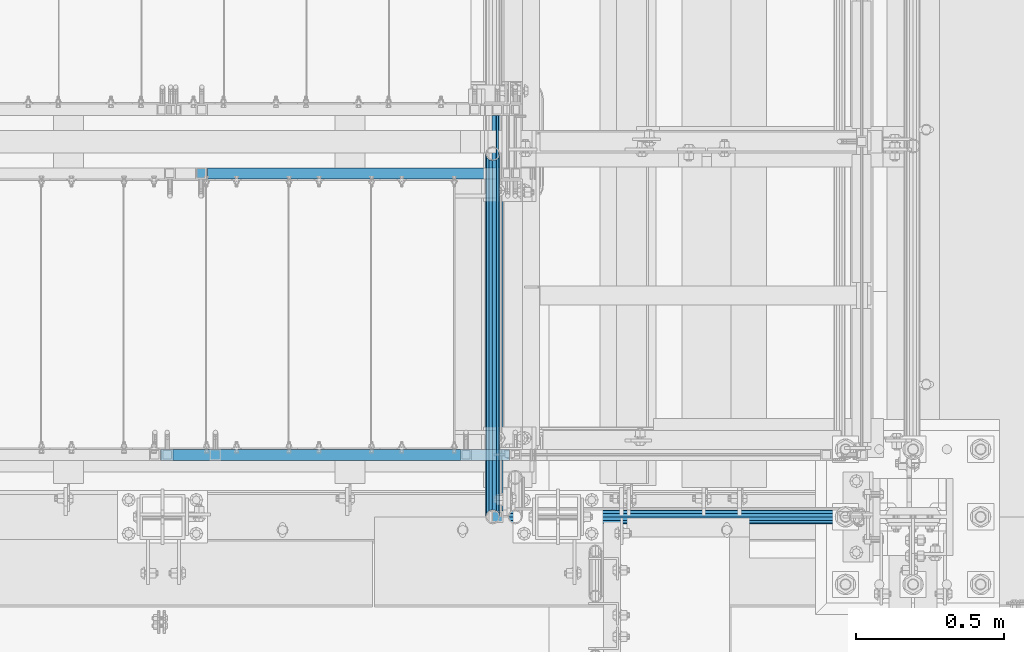
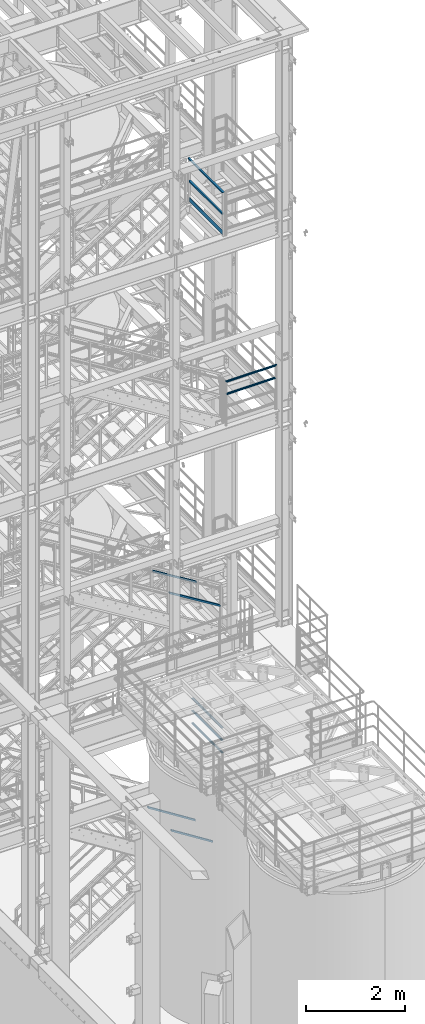
# One storey, part 950 of 1876: 8 beams, 4 members, 7 elements without a shape of their own.
"""IFC2X3 building model written with IfcOpenShell, lengths in millimetres."""

import ifcopenshell
import ifcopenshell.guid

model = None  # the IFC model being written
_history = None  # IfcOwnerHistory: only IFC2X3 demands one
_inside = {}  # id of a spatial element -> (the spatial element, [elements in it])
_under = {}  # id of a project, library or spatial element -> (it, [spatial elements below it])
_declared = {}  # id of a project -> (the project, [libraries it declares])
_typed = {}  # id of a type object -> (the type object, [elements of that type])
_made_of = {}  # id of a material, layer set ... -> (it, [elements and type objects made of it])


def new_model(schema):
    """Start an empty IFC model of exactly this schema.

    Asked for "IFC4X3", IfcOpenShell would pick the latest addendum, in which some entities
    have other attributes; the version numbers below select the first issue.
    IFC2X3 requires an IfcOwnerHistory on every rooted entity: one is made here for all.
    """
    global model, _history
    if schema == "IFC4X3":
        model = ifcopenshell.file(schema_version=(4, 3, 0, 0))
    else:
        model = ifcopenshell.file(schema=schema)
    _inside.clear()
    _under.clear()
    _declared.clear()
    _typed.clear()
    _made_of.clear()
    _history = None
    if model.schema == "IFC2X3":
        org = make("IfcOrganization", Name="unknown")
        user = make(
            "IfcPersonAndOrganization",
            ThePerson=make("IfcPerson", FamilyName="unknown"),
            TheOrganization=org,
        )
        app = make(
            "IfcApplication",
            ApplicationDeveloper=org,
            Version="unknown",
            ApplicationFullName="unknown",
            ApplicationIdentifier="unknown",
        )
        _history = make(
            "IfcOwnerHistory",
            OwningUser=user,
            OwningApplication=app,
            ChangeAction="ADDED",
            CreationDate=0,
        )
    return model


def make(cls, **values):
    """One entity of the class cls with the attributes given. An attribute that is None is left unset."""
    return model.create_entity(
        cls, **{name: value for name, value in values.items() if value is not None}
    )


def rooted(cls, **values):
    """An entity with a GlobalId (a new one), such as an element, a storey or a relation."""
    return make(cls, GlobalId=ifcopenshell.guid.new(), OwnerHistory=_history, **values)


def si_unit(unit_type, name, prefix=None):
    """IfcSIUnit, for example si_unit("LENGTHUNIT", "METRE", prefix="MILLI")."""
    return make("IfcSIUnit", UnitType=unit_type, Prefix=prefix, Name=name)


def assignment(units):
    """IfcUnitAssignment: the units of a project."""
    return None if units is None else make("IfcUnitAssignment", Units=units)


def point(xyz):
    """IfcCartesianPoint."""
    return None if xyz is None else make("IfcCartesianPoint", Coordinates=xyz)


def direction(xyz):
    """IfcDirection."""
    return None if xyz is None else make("IfcDirection", DirectionRatios=xyz)


def frame(location, z_axis=None, x_axis=None):
    """IfcAxis2Placement3D, a coordinate frame: its origin and axes. An axis left out is left unset."""
    return make(
        "IfcAxis2Placement3D",
        Location=point(location),
        Axis=direction(z_axis),
        RefDirection=direction(x_axis),
    )


def origin_with_axes():
    """The frame at (0, 0, 0) with the z axis (0, 0, 1) and the x axis (1, 0, 0) written out."""
    return frame((0.0, 0.0, 0.0), z_axis=(0.0, 0.0, 1.0), x_axis=(1.0, 0.0, 0.0))


def place(relative_to, where):
    """IfcLocalPlacement: puts the frame where relative to a parent placement (None: the world)."""
    return make(
        "IfcLocalPlacement", PlacementRelTo=relative_to, RelativePlacement=where
    )


def context(
    kind, dimensions, precision=None, world=None, true_north=None, identifier=None
):
    """IfcGeometricRepresentationContext, for example the 3D "Model" context."""
    return make(
        "IfcGeometricRepresentationContext",
        ContextIdentifier=identifier,
        ContextType=kind,
        CoordinateSpaceDimension=dimensions,
        Precision=precision,
        WorldCoordinateSystem=world,
        TrueNorth=true_north,
    )


def subcontext(parent, identifier, kind, view, scale=None):
    """IfcGeometricRepresentationSubContext, for example "Body" below "Model"."""
    return make(
        "IfcGeometricRepresentationSubContext",
        ContextIdentifier=identifier,
        ContextType=kind,
        ParentContext=parent,
        TargetScale=scale,
        TargetView=view,
    )


def project(units=None, contexts=None):
    """IfcProject with its units and contexts."""
    return rooted(
        "IfcProject",
        Name="project",
        RepresentationContexts=contexts,
        UnitsInContext=assignment(units),
    )


def spatial(cls, under=None, at=None, **own):
    """A site, building, storey or space (cls), placed at a placement, below another one or the project."""
    s = rooted(cls, ObjectPlacement=at, **own)
    if under is not None:
        _under.setdefault(under.id(), (under, []))[1].append(s)
    return s


def faces_of(points, faces, orient=None, outer=None):
    """IfcFace entities. A face is a list of loops; a loop is a list of indices into points, from 0.

    orient and outer hold one flag for each loop. By default every Orientation is true, the
    first loop of a face is its IfcFaceOuterBound and the others are IfcFaceBound.
    """
    made = []
    for i, loops in enumerate(faces):
        bounds = []
        for j, loop in enumerate(loops):
            is_outer = j == 0 if outer is None else outer[i][j]
            bounds.append(
                make(
                    "IfcFaceOuterBound" if is_outer else "IfcFaceBound",
                    Bound=make("IfcPolyLoop", Polygon=[points[k] for k in loop]),
                    Orientation=True if orient is None else orient[i][j],
                )
            )
        made.append(make("IfcFace", Bounds=bounds))
    return made


def faceted_brep(points, faces, orient=None, outer=None, voids=None):
    """IfcFacetedBrep: a solid bounded by flat faces; with voids (closed shells), ...WithVoids."""
    shared = [point(p) for p in points]
    hull = make("IfcClosedShell", CfsFaces=faces_of(shared, faces, orient, outer))
    if voids is None:
        return make("IfcFacetedBrep", Outer=hull)
    return make(
        "IfcFacetedBrepWithVoids",
        Outer=hull,
        Voids=[
            make(cls, CfsFaces=faces_of(shared, fs, o, b)) for cls, fs, o, b in voids
        ],
    )


def shape(context_of_items, identifier, shape_type, items):
    """IfcShapeRepresentation: the items that make up one representation, for example the "Body"."""
    return make(
        "IfcShapeRepresentation",
        ContextOfItems=context_of_items,
        RepresentationIdentifier=identifier,
        RepresentationType=shape_type,
        Items=items,
    )


def material(Name=None, Category=None):
    """IfcMaterial."""
    return make("IfcMaterial", Name=Name, Category=Category)


def made_of(thing, what):
    """Note that an element or type object is made of a material, layer set ...; save() writes the relation."""
    if what is not None:
        _made_of.setdefault(what.id(), (what, []))[1].append(thing)
    return thing


def type_object(cls, material=None, **own):
    """A type object (cls), such as IfcWallType, which elements share."""
    return made_of(rooted(cls, **own), material)


def element(
    cls,
    number,
    at=None,
    inside=None,
    cuts=None,
    type_object=None,
    material=None,
    context=None,
    identifier="Body",
    shape_type=None,
    held_by="IfcProductDefinitionShape",
    body=None,
    shapes=None,
    **own,
):
    """One element of the class cls, such as IfcWall. Its Tag is "e" and its number.

    at: its placement. inside: the storey or other place that contains it. cuts: it is an
    opening in that element (IfcRelVoidsElement). A single representation is given by context,
    identifier, shape_type and body (its items); several are given by shapes. held_by: the class
    of the entity that holds the representations. save() writes the other relations.
    """
    e = rooted(cls, Tag="e%d" % number, ObjectPlacement=at, **own)
    if body is not None:
        shapes = [shape(context, identifier, shape_type, body)]
    if shapes is not None:
        e.Representation = make(held_by, Representations=shapes)
    if inside is not None:
        _inside.setdefault(inside.id(), (inside, []))[1].append(e)
    if cuts is not None:
        rooted(
            "IfcRelVoidsElement", RelatingBuildingElement=cuts, RelatedOpeningElement=e
        )
    if type_object is not None:
        _typed.setdefault(type_object.id(), (type_object, []))[1].append(e)
    return made_of(e, material)


def aggregate(whole, parts):
    """IfcRelAggregates: a whole, such as a stair, and the parts it consists of."""
    return rooted("IfcRelAggregates", RelatingObject=whole, RelatedObjects=parts)


def save(model, path):
    """Write the relations noted so far, then the file.

    IfcRelAggregates (storeys below a building ...), IfcRelContainedInSpatialStructure (elements
    in a storey), IfcRelDefinesByType, IfcRelAssociatesMaterial and IfcRelDeclares: one each for
    every whole, place, type object, material and project.
    """
    for whole, parts in _under.values():
        aggregate(whole, parts)
    for where, things in _inside.values():
        rooted(
            "IfcRelContainedInSpatialStructure",
            RelatedElements=things,
            RelatingStructure=where,
        )
    for kind, things in _typed.values():
        rooted("IfcRelDefinesByType", RelatedObjects=things, RelatingType=kind)
    for what, things in _made_of.values():
        rooted("IfcRelAssociatesMaterial", RelatedObjects=things, RelatingMaterial=what)
    for by, libraries in _declared.values():
        rooted("IfcRelDeclares", RelatingContext=by, RelatedDefinitions=libraries)
    model.write(path)


model = new_model("IFC2X3")

# Units and contexts
model_context = context("Model", 3, precision=1e-05, world=origin_with_axes())
body_context = subcontext(model_context, "Body", "Model", "MODEL_VIEW")
ifc_project = project(units=[si_unit("LENGTHUNIT", "METRE", prefix="MILLI"), si_unit("AREAUNIT", "SQUARE_METRE"), si_unit("VOLUMEUNIT", "CUBIC_METRE"), si_unit("MASSUNIT", "GRAM", prefix="KILO"), si_unit("TIMEUNIT", "SECOND"), si_unit("PLANEANGLEUNIT", "RADIAN"), si_unit("SOLIDANGLEUNIT", "STERADIAN"), si_unit("THERMODYNAMICTEMPERATUREUNIT", "DEGREE_CELSIUS"), si_unit("LUMINOUSINTENSITYUNIT", "LUMEN")], contexts=[model_context])

# Site, building, storey
site_placement = place(None, origin_with_axes())
site = spatial("IfcSite", under=ifc_project, at=site_placement, CompositionType="ELEMENT")
building_placement = place(site_placement, origin_with_axes())
building = spatial("IfcBuilding", under=site, at=building_placement, Name="Undefined", CompositionType="ELEMENT")
storey_placement = place(building_placement, origin_with_axes())
storey = spatial("IfcBuildingStorey", under=building, at=storey_placement, Name="Undefined", CompositionType="ELEMENT", Elevation=0.0)

# Assembly, beams
assembly_1_placement = place(storey_placement, origin_with_axes())
assembly_1 = element("IfcElementAssembly", 1, at=assembly_1_placement, inside=storey, Name="RAIL", AssemblyPlace="NOTDEFINED", PredefinedType="RIGID_FRAME")
ifc_material_1 = material()
beam_type_1 = type_object("IfcBeamType", Name="PIPE1-1/2SCH40", PredefinedType="NOTDEFINED")
beam_1_placement = place(assembly_1_placement, frame((6273.80016410903, -7112.0, 14081.125), z_axis=(0.0, 0.0, -1.0), x_axis=(1.0, 0.0, 0.0)))
beam_1 = element("IfcBeam", 2, at=beam_1_placement, type_object=beam_type_1, material=ifc_material_1, Name="RAIL", ObjectType="PIPE1-1/2SCH40", context=body_context, shape_type="Brep", body=[
    faceted_brep([(0.0, 24.1299999999992, 0.0), (12.0650000000064, 20.8971929933177, -12.0649999999987), (12.0650000000064, 20.8971929933177, 12.0649999999987), (12.0650000000064, -20.8971929933177, 12.0649999999987), (12.0650000000064, -20.8971929933177, -12.0649999999987), (0.0, -24.1299999999992, 0.0), (20.8971929933249, -12.0650000000005, 20.8971929933177), (20.8971929933249, -12.0650000000005, 15.8661214311796), (15.2545715621445, -17.7076214311801, 10.2235000000001), (12.5151929933249, -20.4470000000001, 0.0), (15.2545715621445, -17.7076214311801, -10.2235000000001), (20.8971929933249, -12.0650000000005, -15.8661214311796), (20.8971929933249, -12.0650000000005, -20.8971929933177), (24.1300000000063, 0.0, -20.4470000000001), (24.1300000000063, 0.0, -24.130000000001), (21.3906214311868, -10.2235000000001, -17.7076214311819), (21.3906214311868, 10.2235000000001, -17.7076214311819), (20.8971929933249, 12.0650000000005, -15.8661214311796), (20.8971929933249, 12.0650000000005, -20.8971929933177), (15.2545715621445, 17.7076214311801, -10.2235000000001), (12.5151929933249, 20.4470000000001, 0.0), (15.2545715621445, 17.7076214311801, 10.2235000000001), (20.8971929933249, 12.0650000000005, 15.8661214311796), (20.8971929933249, 12.0650000000005, 20.8971929933177), (21.3906214311868, 10.2235000000001, 17.7076214311819), (24.1300000000064, 0.0, 20.4470000000001), (24.1300000000064, 0.0, 24.130000000001), (21.3906214311868, -10.2235000000001, 17.7076214311819), (1154.11233589097, 24.1300000000001, 0.0), (1142.04733589097, 20.8971929933186, -12.0649999999996), (1133.21514289765, 12.0649999999996, -20.8971929933186), (1154.11233589097, -24.1300000000001, 0.0), (1142.04733589097, -20.8971929933186, -12.0649999999996), (1142.04733589097, -20.8971929933186, 12.0649999999996), (1133.21514289765, -12.0649999999996, 20.8971929933186), (1133.21514289765, -12.0649999999996, -20.8971929933186), (1129.98233589097, 0.0, -24.1300000000001), (1132.72171445979, 10.2235000000001, -17.7076214311801), (1129.98233589097, 0.0, -20.4470000000001), (1133.21514289765, 12.0649999999996, -15.8661214311805), (1133.21514289765, -12.0649999999996, -15.8661214311805), (1132.72171445979, -10.2235000000001, -17.7076214311801), (1138.85776432883, -17.7076214311801, -10.2235000000001), (1141.59714289765, -20.4470000000001, 0.0), (1138.85776432883, -17.7076214311801, 10.2235000000001), (1133.21514289765, -12.0649999999996, 15.8661214311805), (1132.72171445979, -10.2235000000001, 17.7076214311801), (1129.98233589097, 0.0, 20.4470000000001), (1129.98233589097, 0.0, 24.1300000000001), (1133.21514289765, 12.0649999999996, 20.8971929933186), (1142.04733589097, 20.8971929933186, 12.0649999999996), (1133.21514289765, 12.0649999999996, 15.8661214311805), (1138.85776432883, 17.7076214311801, 10.2235000000001), (1141.59714289765, 20.4470000000001, 0.0), (1138.85776432883, 17.7076214311801, -10.2235000000001), (1132.72171445979, 10.2235000000001, 17.7076214311801)], [[[0, 1, 2]], [[3, 4, 5]], [[6, 7, 8, 9, 10, 11, 12, 4, 3]], [[13, 14, 12, 11, 15]], [[16, 17, 18, 14, 13]], [[2, 1, 18, 17, 19, 20, 21, 22, 23]], [[23, 22, 24, 25, 26]], [[26, 25, 27, 7, 6]], [[1, 0, 28, 29]], [[18, 1, 29, 30]], [[31, 32, 33]], [[6, 3, 33, 34]], [[3, 5, 31, 33]], [[5, 4, 32, 31]], [[4, 12, 35, 32]], [[12, 14, 36, 35]], [[14, 18, 30, 36]], [[37, 38, 36, 30, 39]], [[40, 35, 36, 38, 41]], [[33, 32, 35, 40, 42, 43, 44, 45, 34]], [[34, 45, 46, 47, 48]], [[26, 6, 34, 48]], [[2, 23, 49, 50]], [[23, 26, 48, 49]], [[0, 2, 50, 28]], [[28, 50, 29]], [[49, 51, 52, 53, 54, 39, 30, 29, 50]], [[48, 47, 55, 51, 49]], [[25, 24, 55, 47]], [[55, 24, 22, 21, 52, 51]], [[21, 20, 53, 52]], [[20, 19, 54, 53]], [[19, 17, 16, 37, 39, 54]], [[16, 13, 38, 37]], [[13, 15, 41, 38]], [[41, 15, 11, 10, 42, 40]], [[10, 9, 43, 42]], [[9, 8, 44, 43]], [[8, 7, 27, 46, 45, 44]], [[27, 25, 47, 46]]]),
])
beam_2_placement = place(assembly_1_placement, frame((6249.67016410903, -7112.0, 14385.925), z_axis=(0.0, 0.0, -1.0), x_axis=(1.0, 0.0, 0.0)))
beam_2 = element("IfcBeam", 3, at=beam_2_placement, type_object=beam_type_1, material=ifc_material_1, Name="RAIL", ObjectType="PIPE1-1/2SCH40", context=body_context, shape_type="Brep", body=[
    faceted_brep([(24.1300000000001, -20.4469999999999, 0.0), (34.3535000000002, -17.7076214311803, 10.2235000000001), (1168.01883589097, -17.7076214311801, 10.2235000000001), (1178.24233589097, -20.4470000000001, 0.0), (41.8376214311802, -10.2235000000001, 17.7076214311819), (1160.53471445979, -10.2235000000001, 17.7076214311801), (44.5770000000002, 0.0, 20.4470000000001), (1157.79533589097, 0.0, 20.4470000000001), (41.8376214311802, 10.2235000000001, 17.7076214311819), (1160.53471445979, 10.2235000000001, 17.7076214311801), (34.3535000000002, 17.7076214311803, 10.2235000000001), (1168.01883589097, 17.7076214311801, 10.2235000000001), (24.1300000000001, 20.4469999999999, 0.0), (1178.24233589097, 20.4470000000001, 0.0), (13.9065000000001, 17.7076214311803, -10.2235000000001), (1188.46583589097, 17.7076214311801, -10.2235000000001), (6.42237856882002, 10.2235000000001, -17.7076214311819), (1195.94995732215, 10.2235000000001, -17.7076214311801), (3.68299999999999, 0.0, -20.4470000000001), (1198.68933589097, 0.0, -20.4470000000001), (6.42237856882002, -10.2235000000001, -17.7076214311819), (1195.94995732215, -10.2235000000001, -17.7076214311801), (13.9065000000001, -17.7076214311803, -10.2235000000001), (1188.46583589097, -17.7076214311801, -10.2235000000001), (24.1299999999854, -24.1299999999992, 0.0), (12.0650000000064, -20.8971929933177, -12.0649999999987), (1190.30733589097, -20.8971929933186, -12.0649999999996), (1178.24233589097, -24.1300000000001, 0.0), (3.23280700668147, -12.0650000000001, -20.8971929933177), (1199.13952888429, -12.0649999999996, -20.8971929933186), (-1.45519152283669e-11, 0.0, -24.130000000001), (1202.37233589097, 0.0, -24.1300000000001), (3.23280700668147, 12.0650000000001, -20.8971929933177), (1199.13952888429, 12.0649999999996, -20.8971929933186), (12.0650000000064, 20.8971929933177, -12.0649999999987), (1190.30733589097, 20.8971929933186, -12.0649999999996), (24.1300000000047, 24.1299999999992, 0.0), (1178.24233589097, 24.1300000000001, 0.0), (36.1949999999997, 20.8971929933184, 12.0649999999987), (1166.17733589097, 20.8971929933186, 12.0649999999996), (45.0271929933187, 12.0650000000001, 20.8971929933177), (1157.34514289765, 12.0649999999996, 20.8971929933186), (48.2600000000002, 0.0, 24.130000000001), (1154.11233589097, 0.0, 24.1300000000001), (45.0271929933187, -12.0650000000001, 20.8971929933177), (1157.34514289765, -12.0649999999996, 20.8971929933186), (36.1949999999997, -20.8971929933184, 12.0649999999987), (1166.17733589097, -20.8971929933186, 12.0649999999996)], [[[0, 1, 2, 3]], [[1, 4, 5, 2]], [[4, 6, 7, 5]], [[6, 8, 9, 7]], [[8, 10, 11, 9]], [[10, 12, 13, 11]], [[12, 14, 15, 13]], [[14, 16, 17, 15]], [[16, 18, 19, 17]], [[18, 20, 21, 19]], [[20, 22, 23, 21]], [[22, 0, 3, 23]], [[24, 25, 26, 27]], [[25, 28, 29, 26]], [[28, 30, 31, 29]], [[30, 32, 33, 31]], [[32, 34, 35, 33]], [[34, 36, 37, 35]], [[36, 38, 39, 37]], [[38, 40, 41, 39]], [[40, 42, 43, 41]], [[42, 44, 45, 43]], [[44, 46, 47, 45]], [[46, 24, 27, 47]], [[29, 31, 33, 35, 37, 39, 41, 43, 45, 47, 27, 26], [5, 7, 9, 11, 13, 15, 17, 19, 21, 23, 3, 2]], [[46, 44, 42, 40, 38, 36, 34, 32, 30, 28, 25, 24], [22, 20, 18, 16, 14, 12, 10, 8, 6, 4, 1, 0]]]),
])
aggregate(assembly_1, [beam_1, beam_2])

assembly_2_placement = place(storey_placement, origin_with_axes())
assembly_2 = element("IfcElementAssembly", 4, at=assembly_2_placement, inside=storey, Name="RAIL", AssemblyPlace="NOTDEFINED", PredefinedType="RIGID_FRAME")
beam_3_placement = place(assembly_2_placement, frame((6197.60000000158, -5883.27500095479, 5292.725), z_axis=(0.0, 0.0, 1.0), x_axis=(0.0, -1.0, 0.0)))
beam_3 = element("IfcBeam", 5, at=beam_3_placement, type_object=beam_type_1, material=ifc_material_1, Name="RAIL", ObjectType="PIPE1-1/2SCH40", context=body_context, shape_type="Brep", body=[
    faceted_brep([(1207.82780681642, -12.0649999999996, 20.8971929933186), (1207.82780681642, -12.0649999999432, 15.8661214312369), (1207.33437837857, -10.2235000000001, 17.7076214311801), (1204.59499980973, 2.72848410531878e-12, 20.4470000000001), (1204.59499980973, 2.72848410531878e-12, 24.1300000000001), (1207.33437837854, 10.2235000000001, 17.7076214311801), (1207.82780681642, 12.065000000056, 15.8661214311242), (1207.82780681642, 12.0649999999996, 20.8971929933186), (1228.72499980973, 24.1300000000001, 0.0), (1216.65999980973, 20.8971929933186, 12.0649999999996), (1216.65999980973, 20.8971929933186, -12.0649999999996), (1213.47042824754, 17.7076214311801, 10.2235000000001), (1216.20980681636, 20.4470000000001, 0.0), (1213.47042824754, 17.7076214311801, -10.2235000000001), (1207.82780681642, 12.065000000056, -15.8661214311242), (1207.82780681642, 12.0649999999996, -20.8971929933186), (1207.33437837854, 10.2235000000001, -17.7076214311801), (1204.59499980973, 0.0, -20.4470000000001), (1204.59499980973, 0.0, -24.1300000000001), (1207.82780681642, -12.0649999999432, -15.8661214312369), (1207.82780681642, -12.0649999999996, -20.8971929933186), (1207.33437837857, -10.2235000000001, -17.7076214311801), (1228.72499980973, -24.1299999999437, 0.0), (1216.65999980973, -20.8971929933186, -12.0649999999996), (1216.65999980973, -20.8971929933186, 12.0649999999996), (1213.47042824765, -17.7076214311801, -10.2235000000001), (1216.20980681647, -20.4470000000001, 0.0), (1213.47042824765, -17.7076214311801, 10.2235000000001), (12.0650000000064, -20.8971929933177, -12.0649999999987), (20.8971929933249, -12.0650000000005, -20.8971929933177), (0.0, 24.1299999999992, 0.0), (12.0650000000064, 20.8971929933177, -12.0649999999987), (12.0650000000064, 20.8971929933177, 12.0649999999987), (20.8971929933249, 12.0650000000005, 20.8971929933177), (24.1300000000064, 0.0, 24.130000000001), (20.8971929933249, 12.0650000000005, -20.8971929933177), (24.1300000000063, 0.0, -24.130000000001), (24.1300000000063, 0.0, -20.4470000000001), (20.8971929933249, -12.0650000000005, -15.8661214311796), (21.3906214311868, -10.2235000000001, -17.7076214311819), (21.3906214311868, 10.2235000000001, -17.7076214311819), (20.8971929933249, 12.0650000000005, -15.8661214311796), (15.2545715621445, 17.7076214311801, -10.2235000000001), (12.5151929933249, 20.4470000000001, 0.0), (15.2545715621445, 17.7076214311801, 10.2235000000001), (20.8971929933249, 12.0650000000005, 15.8661214311796), (21.3906214311868, 10.2235000000001, 17.7076214311819), (24.1300000000064, 0.0, 20.4470000000001), (21.3906214311868, -10.2235000000001, 17.7076214311819), (20.8971929933249, -12.0650000000005, 15.8661214311796), (20.8971929933249, -12.0650000000005, 20.8971929933177), (12.0650000000064, -20.8971929933177, 12.0649999999987), (0.0, -24.1299999999992, 0.0), (15.2545715621445, -17.7076214311801, 10.2235000000001), (12.5151929933249, -20.4470000000001, 0.0), (15.2545715621445, -17.7076214311801, -10.2235000000001)], [[[0, 1, 2, 3, 4]], [[4, 3, 5, 6, 7]], [[8, 9, 10]], [[7, 6, 11, 12, 13, 14, 15, 10, 9]], [[16, 17, 18, 15, 14]], [[19, 20, 18, 17, 21]], [[22, 23, 24]], [[24, 23, 20, 19, 25, 26, 27, 1, 0]], [[28, 29, 20, 23]], [[30, 31, 32]], [[33, 34, 4, 7]], [[32, 33, 7, 9]], [[30, 32, 9, 8]], [[31, 30, 8, 10]], [[35, 31, 10, 15]], [[36, 35, 15, 18]], [[29, 36, 18, 20]], [[37, 36, 29, 38, 39]], [[40, 41, 35, 36, 37]], [[32, 31, 35, 41, 42, 43, 44, 45, 33]], [[33, 45, 46, 47, 34]], [[34, 47, 48, 49, 50]], [[34, 50, 0, 4]], [[50, 51, 24, 0]], [[51, 52, 22, 24]], [[52, 28, 23, 22]], [[51, 28, 52]], [[50, 49, 53, 54, 55, 38, 29, 28, 51]], [[55, 54, 26, 25]], [[21, 39, 38, 55, 25, 19]], [[37, 39, 21, 17]], [[40, 37, 17, 16]], [[42, 41, 40, 16, 14, 13]], [[43, 42, 13, 12]], [[44, 43, 12, 11]], [[5, 46, 45, 44, 11, 6]], [[47, 46, 5, 3]], [[48, 47, 3, 2]], [[53, 49, 48, 2, 1, 27]], [[54, 53, 27, 26]]]),
])
beam_4_placement = place(assembly_2_placement, frame((6197.59999999995, -7112.00000000001, 5597.525), z_axis=(0.0, 0.0, -1.0), x_axis=(0.0, 1.0, 0.0)))
beam_4 = element("IfcBeam", 6, at=beam_4_placement, type_object=beam_type_1, material=ifc_material_1, Name="RAIL", ObjectType="PIPE1-1/2SCH40", context=body_context, shape_type="Brep", body=[
    faceted_brep([(0.0, 24.1299999999992, 0.0), (12.0650000000064, 20.8971929933177, -12.0649999999987), (12.0650000000064, 20.8971929933177, 12.0649999999987), (12.0650000000064, -20.8971929933177, 12.0649999999987), (12.0650000000064, -20.8971929933177, -12.0649999999987), (0.0, -24.1299999999992, 0.0), (20.8971929933249, -12.0650000000005, 20.8971929933177), (20.8971929933249, -12.0650000000005, 15.8661214311796), (15.2545715621445, -17.7076214311801, 10.2235000000001), (12.5151929933249, -20.4470000000001, 0.0), (15.2545715621445, -17.7076214311801, -10.2235000000001), (20.8971929933249, -12.0650000000005, -15.8661214311796), (20.8971929933249, -12.0650000000005, -20.8971929933177), (24.1300000000063, 0.0, -20.4470000000001), (24.1300000000063, 0.0, -24.130000000001), (21.3906214311868, -10.2235000000001, -17.7076214311819), (21.3906214311868, 10.2235000000001, -17.7076214311819), (20.8971929933249, 12.0650000000005, -15.8661214311796), (20.8971929933249, 12.0650000000005, -20.8971929933177), (15.2545715621445, 17.7076214311801, -10.2235000000001), (12.5151929933249, 20.4470000000001, 0.0), (15.2545715621445, 17.7076214311801, 10.2235000000001), (20.8971929933249, 12.0650000000005, 15.8661214311796), (20.8971929933249, 12.0650000000005, 20.8971929933177), (21.3906214311868, 10.2235000000001, 17.7076214311819), (24.1300000000064, 0.0, 20.4470000000001), (24.1300000000064, 0.0, 24.130000000001), (21.3906214311868, -10.2235000000001, 17.7076214311819), (1228.72499980973, 24.1300000000001, 0.0), (1216.65999980973, 20.8971929933186, -12.0649999999996), (1207.82780681642, 12.0649999999996, -20.8971929933186), (1228.72499980973, -24.1299999999437, 0.0), (1216.65999980973, -20.8971929933186, -12.0649999999996), (1216.65999980973, -20.8971929933186, 12.0649999999996), (1207.82780681642, -12.0649999999996, 20.8971929933186), (1207.82780681642, -12.0649999999996, -20.8971929933186), (1204.59499980973, 0.0, -24.1300000000001), (1207.33437837854, 10.2235000000001, -17.7076214311801), (1204.59499980973, 0.0, -20.4470000000001), (1207.82780681642, 12.065000000056, -15.8661214311242), (1207.82780681642, -12.0649999999432, -15.8661214312369), (1207.33437837857, -10.2235000000001, -17.7076214311801), (1213.47042824765, -17.7076214311801, -10.2235000000001), (1216.20980681647, -20.4470000000001, 0.0), (1213.47042824765, -17.7076214311801, 10.2235000000001), (1207.82780681642, -12.0649999999432, 15.8661214312369), (1207.33437837857, -10.2235000000001, 17.7076214311801), (1204.59499980973, 2.72848410531878e-12, 20.4470000000001), (1204.59499980973, 2.72848410531878e-12, 24.1300000000001), (1207.82780681642, 12.0649999999996, 20.8971929933186), (1216.65999980973, 20.8971929933186, 12.0649999999996), (1207.82780681642, 12.065000000056, 15.8661214311242), (1213.47042824754, 17.7076214311801, 10.2235000000001), (1216.20980681636, 20.4470000000001, 0.0), (1213.47042824754, 17.7076214311801, -10.2235000000001), (1207.33437837854, 10.2235000000001, 17.7076214311801)], [[[0, 1, 2]], [[3, 4, 5]], [[6, 7, 8, 9, 10, 11, 12, 4, 3]], [[13, 14, 12, 11, 15]], [[16, 17, 18, 14, 13]], [[2, 1, 18, 17, 19, 20, 21, 22, 23]], [[23, 22, 24, 25, 26]], [[26, 25, 27, 7, 6]], [[1, 0, 28, 29]], [[18, 1, 29, 30]], [[31, 32, 33]], [[6, 3, 33, 34]], [[3, 5, 31, 33]], [[5, 4, 32, 31]], [[4, 12, 35, 32]], [[12, 14, 36, 35]], [[14, 18, 30, 36]], [[37, 38, 36, 30, 39]], [[40, 35, 36, 38, 41]], [[33, 32, 35, 40, 42, 43, 44, 45, 34]], [[34, 45, 46, 47, 48]], [[26, 6, 34, 48]], [[2, 23, 49, 50]], [[23, 26, 48, 49]], [[0, 2, 50, 28]], [[28, 50, 29]], [[49, 51, 52, 53, 54, 39, 30, 29, 50]], [[48, 47, 55, 51, 49]], [[25, 24, 55, 47]], [[55, 24, 22, 21, 52, 51]], [[21, 20, 53, 52]], [[20, 19, 54, 53]], [[19, 17, 16, 37, 39, 54]], [[16, 13, 38, 37]], [[13, 15, 41, 38]], [[41, 15, 11, 10, 42, 40]], [[10, 9, 43, 42]], [[9, 8, 44, 43]], [[8, 7, 27, 46, 45, 44]], [[27, 25, 47, 46]]]),
])
beam_5_placement = place(assembly_2_placement, frame((6197.59999999995, -7112.00000000001, 5902.325), z_axis=(0.0, 0.0, -1.0), x_axis=(0.0, 1.0, 0.0)))
beam_5 = element("IfcBeam", 7, at=beam_5_placement, type_object=beam_type_1, material=ifc_material_1, Name="RAIL", ObjectType="PIPE1-1/2SCH40", context=body_context, shape_type="Brep", body=[
    faceted_brep([(0.0, 24.1299999999992, 0.0), (12.0650000000064, 20.8971929933177, -12.0649999999987), (12.0650000000064, 20.8971929933177, 12.0649999999987), (12.0650000000064, -20.8971929933177, 12.0649999999987), (12.0650000000064, -20.8971929933177, -12.0649999999987), (0.0, -24.1299999999992, 0.0), (20.8971929933249, -12.0650000000005, 20.8971929933177), (20.8971929933249, -12.0650000000005, 15.8661214311796), (15.2545715621445, -17.7076214311801, 10.2235000000001), (12.5151929933249, -20.4470000000001, 0.0), (15.2545715621445, -17.7076214311801, -10.2235000000001), (20.8971929933249, -12.0650000000005, -15.8661214311796), (20.8971929933249, -12.0650000000005, -20.8971929933177), (24.1300000000063, 0.0, -20.4470000000001), (24.1300000000063, 0.0, -24.130000000001), (21.3906214311868, -10.2235000000001, -17.7076214311819), (21.3906214311868, 10.2235000000001, -17.7076214311819), (20.8971929933249, 12.0650000000005, -15.8661214311796), (20.8971929933249, 12.0650000000005, -20.8971929933177), (15.2545715621445, 17.7076214311801, -10.2235000000001), (12.5151929933249, 20.4470000000001, 0.0), (15.2545715621445, 17.7076214311801, 10.2235000000001), (20.8971929933249, 12.0650000000005, 15.8661214311796), (20.8971929933249, 12.0650000000005, 20.8971929933177), (21.3906214311868, 10.2235000000001, 17.7076214311819), (24.1300000000064, 0.0, 20.4470000000001), (24.1300000000064, 0.0, 24.130000000001), (21.3906214311868, -10.2235000000001, 17.7076214311819), (1228.72499980973, 24.1300000000001, 0.0), (1216.65999980973, 20.8971929933186, -12.0649999999996), (1207.82780681642, 12.0649999999996, -20.8971929933186), (1228.72499980973, -24.1299999999437, 0.0), (1216.65999980973, -20.8971929933186, -12.0649999999996), (1216.65999980973, -20.8971929933186, 12.0649999999996), (1207.82780681642, -12.0649999999996, 20.8971929933186), (1207.82780681642, -12.0649999999996, -20.8971929933186), (1204.59499980973, 0.0, -24.1300000000001), (1207.33437837854, 10.2235000000001, -17.7076214311801), (1204.59499980973, 0.0, -20.4470000000001), (1207.82780681642, 12.065000000056, -15.8661214311242), (1207.82780681642, -12.0649999999432, -15.8661214312369), (1207.33437837857, -10.2235000000001, -17.7076214311801), (1213.47042824765, -17.7076214311801, -10.2235000000001), (1216.20980681647, -20.4470000000001, 0.0), (1213.47042824765, -17.7076214311801, 10.2235000000001), (1207.82780681642, -12.0649999999432, 15.8661214312369), (1207.33437837857, -10.2235000000001, 17.7076214311801), (1204.59499980973, 2.72848410531878e-12, 20.4470000000001), (1204.59499980973, 2.72848410531878e-12, 24.1300000000001), (1207.82780681642, 12.0649999999996, 20.8971929933186), (1216.65999980973, 20.8971929933186, 12.0649999999996), (1207.82780681642, 12.065000000056, 15.8661214311242), (1213.47042824754, 17.7076214311801, 10.2235000000001), (1216.20980681636, 20.4470000000001, 0.0), (1213.47042824754, 17.7076214311801, -10.2235000000001), (1207.33437837854, 10.2235000000001, 17.7076214311801)], [[[0, 1, 2]], [[3, 4, 5]], [[6, 7, 8, 9, 10, 11, 12, 4, 3]], [[13, 14, 12, 11, 15]], [[16, 17, 18, 14, 13]], [[2, 1, 18, 17, 19, 20, 21, 22, 23]], [[23, 22, 24, 25, 26]], [[26, 25, 27, 7, 6]], [[1, 0, 28, 29]], [[18, 1, 29, 30]], [[31, 32, 33]], [[6, 3, 33, 34]], [[3, 5, 31, 33]], [[5, 4, 32, 31]], [[4, 12, 35, 32]], [[12, 14, 36, 35]], [[14, 18, 30, 36]], [[37, 38, 36, 30, 39]], [[40, 35, 36, 38, 41]], [[33, 32, 35, 40, 42, 43, 44, 45, 34]], [[34, 45, 46, 47, 48]], [[26, 6, 34, 48]], [[2, 23, 49, 50]], [[23, 26, 48, 49]], [[0, 2, 50, 28]], [[28, 50, 29]], [[49, 51, 52, 53, 54, 39, 30, 29, 50]], [[48, 47, 55, 51, 49]], [[25, 24, 55, 47]], [[55, 24, 22, 21, 52, 51]], [[21, 20, 53, 52]], [[20, 19, 54, 53]], [[19, 17, 16, 37, 39, 54]], [[16, 13, 38, 37]], [[13, 15, 41, 38]], [[41, 15, 11, 10, 42, 40]], [[10, 9, 43, 42]], [[9, 8, 44, 43]], [[8, 7, 27, 46, 45, 44]], [[27, 25, 47, 46]]]),
])
aggregate(assembly_2, [beam_3, beam_4, beam_5])

assembly_3_placement = place(storey_placement, origin_with_axes())
assembly_3 = element("IfcElementAssembly", 8, at=assembly_3_placement, inside=storey, Name="RAIL", AssemblyPlace="NOTDEFINED", PredefinedType="RIGID_FRAME")
ifc_material_2 = material(Name="STEEL/A36")
beam_type_2 = type_object("IfcBeamType", PredefinedType="NOTDEFINED")
beam_6_placement = place(assembly_3_placement, frame((6213.47489422174, -7092.95000219293, 18056.225), z_axis=(0.0, 0.0, 1.0), x_axis=(0.0, 1.0, 0.0)))
beam_6 = element("IfcBeam", 9, at=beam_6_placement, type_object=beam_type_2, material=ifc_material_2, Name="PLATE", context=body_context, shape_type="Brep", body=[
    faceted_brep([(0.0, 3.17500000000018, -50.8000000000002), (0.0, 3.17500000000018, 50.8000000000002), (1339.85000038447, 3.1750000004804, 50.7999999999993), (1339.85000038447, 3.1750000004804, -50.7999999999993), (0.0, -3.17500000000018, 50.8000000000002), (1339.85000038447, -3.17499999951997, 50.7999999999993), (0.0, -3.17500000000018, -50.8000000000002), (1339.85000038447, -3.17499999951997, -50.7999999999993)], [[[0, 1, 2, 3]], [[1, 4, 5, 2]], [[4, 6, 7, 5]], [[6, 0, 3, 7]], [[5, 7, 3, 2]], [[6, 4, 1, 0]]]),
])
ifc_material_3 = material()
beam_type_3 = type_object("IfcBeamType", Name="HSS1-1/2X1-1/2X1/8", PredefinedType="NOTDEFINED")
beam_7_placement = place(assembly_3_placement, frame((6213.47499647594, -5734.05000114554, 18516.6000018082), z_axis=(0.0, 0.0, 1.0), x_axis=(0.0, -1.0, 0.0)))
beam_7 = element("IfcBeam", 10, at=beam_7_placement, type_object=beam_type_3, material=ifc_material_3, Name="RAIL", ObjectType="HSS1-1/2X1-1/2X1/8", context=body_context, shape_type="Brep", body=[
    faceted_brep([(19.0500000000002, 15.8749992829999, -15.8749992829999), (19.0500000000002, -15.8749992829999, -15.8749992829999), (1358.8999981862, -15.8749992825406, -15.8749992830017), (1358.8999981862, 15.874999283461, -15.8749992830017), (19.0500000000002, -15.8749992829999, 15.8749992829999), (1358.8999981862, -15.8749992825406, 15.8749992830017), (19.0500000000002, 15.8749992829999, 15.8749992829999), (1358.8999981862, 15.874999283461, 15.8749992830017), (19.0500000000002, 19.0499992349996, -19.0499992350001), (19.0500000000002, 19.0499992349996, 19.0499992350001), (1358.8999981862, 19.0499992354607, 19.0499992350015), (1358.8999981862, 19.0499992354607, -19.0499992350015), (19.0500000000002, -19.0499992349996, 19.0499992350001), (1358.8999981862, -19.0499992345403, 19.0499992350015), (19.0500000000002, -19.0499992349996, -19.0499992350001), (1358.8999981862, -19.0499992345403, -19.0499992350015)], [[[0, 1, 2, 3]], [[1, 4, 5, 2]], [[4, 6, 7, 5]], [[6, 0, 3, 7]], [[8, 9, 10, 11]], [[9, 12, 13, 10]], [[12, 14, 15, 13]], [[14, 8, 11, 15]], [[13, 15, 11, 10], [5, 7, 3, 2]], [[12, 9, 8, 14], [4, 1, 0, 6]]]),
])
beam_8_placement = place(assembly_3_placement, frame((6213.47489203526, -7131.05000065926, 19050.0000018074), z_axis=(0.0, 0.0, -1.0), x_axis=(0.0, 1.0, 0.0)))
beam_8 = element("IfcBeam", 11, at=beam_8_placement, type_object=beam_type_3, material=ifc_material_3, Name="RAIL", ObjectType="HSS1-1/2X1-1/2X1/8", context=body_context, shape_type="Brep", body=[
    faceted_brep([(3.17499995199978, 15.8749992829999, -15.8749992829999), (3.17499995199978, -15.8749992829999, -15.8749992829999), (1412.87499879471, -15.8749992834782, -15.8749992830017), (1412.87499879471, 15.8749992825215, -15.8749992830017), (34.9249985179995, -15.8749992829999, 15.8749992829999), (1381.12500022871, -15.8749992834682, 15.8749992830017), (34.9249985179995, 15.8749992829999, 15.8749992829999), (1381.12500022871, 15.8749992825324, 15.8749992830017), (0.0, 19.0499992349996, -19.0499992350001), (38.0999984699993, 19.0499992349996, 19.0499992350001), (1377.95000027671, 19.0499992345331, 19.0499992350015), (1416.04999874671, 19.0499992345203, -19.0499992350015), (38.0999984699993, -19.0499992349996, 19.0499992350001), (1377.95000027671, -19.0499992354671, 19.0499992350015), (0.0, -19.0499992349996, -19.0499992350001), (1416.04999874671, -19.0499992354798, -19.0499992350015)], [[[0, 1, 2, 3]], [[1, 4, 5, 2]], [[4, 6, 7, 5]], [[6, 0, 3, 7]], [[8, 9, 10, 11]], [[9, 12, 13, 10]], [[12, 14, 15, 13]], [[14, 8, 11, 15]], [[13, 15, 11, 10], [5, 7, 3, 2]], [[14, 12, 9, 8], [6, 4, 1, 0]]]),
])
aggregate(assembly_3, [beam_6, beam_7, beam_8])

# Assembly, member
assembly_4_placement = place(storey_placement, origin_with_axes())
assembly_4 = element("IfcElementAssembly", 12, at=assembly_4_placement, inside=storey, Name="RAIL", AssemblyPlace="NOTDEFINED", PredefinedType="RIGID_FRAME")
member_type = type_object("IfcMemberType", Name="HSS1-1/2X1-1/2X1/8", PredefinedType="NOTDEFINED")
member_1_placement = place(assembly_4_placement, frame((6248.40000001289, -5949.95000114554, 2918.25297879087), z_axis=(0.535697420207059, 0.0, 0.844410015326383), x_axis=(-0.844410015326383, 0.0, 0.535697420207059)))
member_1 = element("IfcMember", 13, at=member_1_placement, type_object=member_type, material=ifc_material_3, Name="RAIL", ObjectType="HSS1-1/2X1-1/2X1/8", context=body_context, shape_type="Brep", body=[
    faceted_brep([(1343.13309186325, -19.0499992349996, 19.0499992346431), (1318.96228559638, -19.0499992349996, -19.0499992353589), (1318.96228559638, 19.0499992349996, -19.0499992353589), (1343.13309186325, 19.0499992349996, 19.0499992346431), (1341.11885795724, -15.8749992829999, 15.8749992826424), (1341.11885795724, 15.8749992829999, 15.8749992826424), (1320.97651950239, 15.8749992829999, -15.8749992833582), (1320.97651950239, -15.8749992829999, -15.8749992833582), (34.6455325374254, 19.0499992349996, 19.049999235012), (34.6455325374254, -19.0499992349996, 19.049999235012), (10.4747262991696, -19.0499992349996, -19.0499992349991), (10.4747262991696, 19.0499992349996, -19.0499992349991), (32.6312986338025, 15.8749992829999, 15.8749992830109), (32.6312986338025, -15.8749992829999, 15.8749992830109), (12.4889602027924, -15.8749992829999, -15.8749992829981), (12.4889602027924, 15.8749992829999, -15.8749992829981)], [[[0, 1, 2, 3], [4, 5, 6, 7]], [[0, 3, 8, 9]], [[2, 1, 10, 11]], [[1, 0, 9, 10]], [[3, 2, 11, 8]], [[10, 9, 8, 11], [12, 13, 14, 15]], [[4, 7, 14, 13]], [[7, 6, 15, 14]], [[6, 5, 12, 15]], [[5, 4, 13, 12]]]),
])
aggregate(assembly_4, [member_1])

assembly_5_placement = place(storey_placement, origin_with_axes())
assembly_5 = element("IfcElementAssembly", 14, at=assembly_5_placement, inside=storey, Name="RAIL", AssemblyPlace="NOTDEFINED", PredefinedType="RIGID_FRAME")
member_2_placement = place(assembly_5_placement, frame((6107.11250134065, -6902.45000114554, 3017.41138811643), z_axis=(0.535697420207059, 0.0, 0.844410015326383), x_axis=(-0.844410015326383, 0.0, 0.535697420207059)))
member_2 = element("IfcMember", 15, at=member_2_placement, type_object=member_type, material=ifc_material_3, Name="RAIL", ObjectType="HSS1-1/2X1-1/2X1/8", context=body_context, shape_type="Brep", body=[
    faceted_brep([(1187.09219031264, -19.0499992349996, 19.0499992346859), (1162.92138404577, -19.0499992349996, -19.0499992353161), (1162.92138404577, 19.0499992349996, -19.0499992353161), (1187.09219031264, 19.0499992349996, 19.0499992346859), (1185.07795640663, -15.8749992829999, 15.8749992826852), (1185.07795640663, 15.8749992829999, 15.8749992826852), (1164.93561795178, 15.8749992829999, -15.8749992833154), (1164.93561795178, -15.8749992829999, -15.8749992833154), (34.6455325374254, 19.0499992349996, 19.049999235012), (34.6455325374254, -19.0499992349996, 19.049999235012), (10.4747262991696, -19.0499992349996, -19.0499992349991), (10.4747262991696, 19.0499992349996, -19.0499992349991), (32.6312986338025, 15.8749992829999, 15.8749992830109), (32.6312986338025, -15.8749992829999, 15.8749992830109), (12.4889602027924, -15.8749992829999, -15.8749992829981), (12.4889602027924, 15.8749992829999, -15.8749992829981)], [[[0, 1, 2, 3], [4, 5, 6, 7]], [[0, 3, 8, 9]], [[2, 1, 10, 11]], [[1, 0, 9, 10]], [[3, 2, 11, 8]], [[10, 9, 8, 11], [12, 13, 14, 15]], [[4, 7, 14, 13]], [[7, 6, 15, 14]], [[6, 5, 12, 15]], [[5, 4, 13, 12]]]),
])
aggregate(assembly_5, [member_2])

assembly_6_placement = place(storey_placement, origin_with_axes())
assembly_6 = element("IfcElementAssembly", 16, at=assembly_6_placement, inside=storey, Name="RAIL", AssemblyPlace="NOTDEFINED", PredefinedType="RIGID_FRAME")
member_3_placement = place(assembly_6_placement, frame((6273.80000035514, -6902.45000114554, 8758.82456218445), z_axis=(0.523955482879573, 0.0, 0.851745649804232), x_axis=(-0.851745649804232, 0.0, 0.523955482879573)))
member_3 = element("IfcMember", 17, at=member_3_placement, type_object=member_type, material=ifc_material_3, Name="RAIL", ObjectType="HSS1-1/2X1-1/2X1/8", context=body_context, shape_type="Brep", body=[
    faceted_brep([(1420.76610761206, -19.0499992349996, 19.0499992362784), (1397.32870807774, -19.0499992349996, -19.0499992337591), (1397.32870807774, 19.0499992349996, -19.0499992337591), (1420.76610761206, 19.0499992349996, 19.0499992362784), (1418.81299093529, -15.8749992829999, 15.874999284275), (1418.81299093529, 15.8749992829999, 15.874999284275), (1399.2818247545, 15.8749992829999, -15.8749992817557), (1399.2818247545, -15.8749992829999, -15.8749992817557), (34.0845307397099, 19.0499992349996, 19.0499992350287), (34.0845307397099, -19.0499992349996, 19.0499992350287), (10.6471616099025, -19.0499992349996, -19.0499992350033), (10.6471616099025, 19.0499992349996, -19.0499992350033), (32.1314140629433, 15.8749992829999, 15.8749992830271), (32.1314140629433, -15.8749992829999, 15.8749992830271), (12.6002676416374, -15.8749992829999, -15.8749992830035), (12.6002676416374, 15.8749992829999, -15.8749992830035)], [[[0, 1, 2, 3], [4, 5, 6, 7]], [[8, 9, 0, 3]], [[10, 11, 2, 1]], [[9, 10, 1, 0]], [[11, 8, 3, 2]], [[10, 9, 8, 11], [12, 13, 14, 15]], [[14, 13, 4, 7]], [[15, 14, 7, 6]], [[12, 15, 6, 5]], [[13, 12, 5, 4]]]),
])
aggregate(assembly_6, [member_3])

assembly_7_placement = place(storey_placement, origin_with_axes())
assembly_7 = element("IfcElementAssembly", 18, at=assembly_7_placement, inside=storey, Name="RAIL", AssemblyPlace="NOTDEFINED", PredefinedType="RIGID_FRAME")
member_4_placement = place(assembly_7_placement, frame((6273.80000035562, -5949.95000114554, 8758.82456218446), z_axis=(0.523955482879573, 0.0, 0.851745649804232), x_axis=(-0.851745649804232, 0.0, 0.523955482879573)))
member_4 = element("IfcMember", 19, at=member_4_placement, type_object=member_type, material=ifc_material_3, Name="RAIL", ObjectType="HSS1-1/2X1-1/2X1/8", context=body_context, shape_type="Brep", body=[
    faceted_brep([(1234.38417612661, -19.0499992349996, 19.049999236111), (1210.94677659227, -19.0499992349996, -19.0499992339264), (1210.94677659227, 19.0499992349996, -19.0499992339264), (1234.38417612661, 19.0499992349996, 19.049999236111), (1232.43105944984, -15.8749992829999, 15.8749992841076), (1232.43105944984, 15.8749992829999, 15.8749992841076), (1212.89989326904, 15.8749992829999, -15.874999281923), (1212.89989326904, -15.8749992829999, -15.874999281923), (34.0845307397099, 19.0499992349996, 19.0499992350287), (34.0845307397099, -19.0499992349996, 19.0499992350287), (10.6471616099025, -19.0499992349996, -19.0499992350033), (10.6471616099025, 19.0499992349996, -19.0499992350033), (32.1314140629433, 15.8749992829999, 15.8749992830271), (32.1314140629433, -15.8749992829999, 15.8749992830271), (12.6002676416374, -15.8749992829999, -15.8749992830035), (12.6002676416374, 15.8749992829999, -15.8749992830035)], [[[0, 1, 2, 3], [4, 5, 6, 7]], [[0, 3, 8, 9]], [[2, 1, 10, 11]], [[1, 0, 9, 10]], [[3, 2, 11, 8]], [[10, 9, 8, 11], [12, 13, 14, 15]], [[4, 7, 14, 13]], [[7, 6, 15, 14]], [[6, 5, 12, 15]], [[5, 4, 13, 12]]]),
])
aggregate(assembly_7, [member_4])

save(model, "model.ifc")
